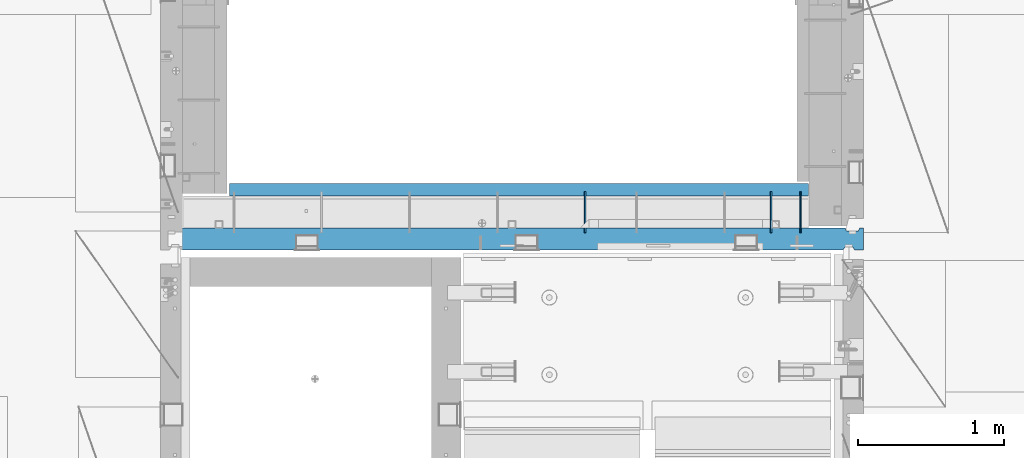
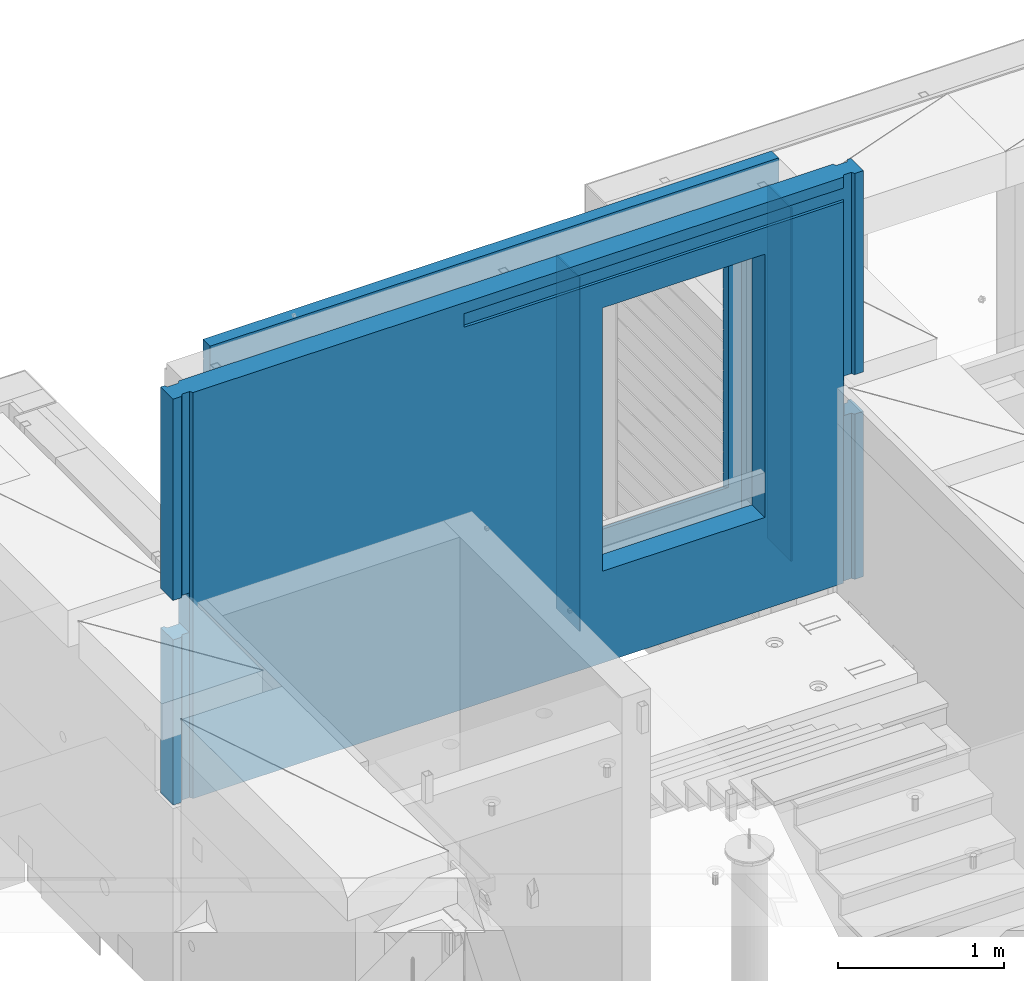
# One storey, part 239 of 350: 5 walls, 1 element without a shape of its own.
"""IFC2X3 building model written with IfcOpenShell, lengths in millimetres."""

import ifcopenshell
import ifcopenshell.guid

model = None  # the IFC model being written
_history = None  # IfcOwnerHistory: only IFC2X3 demands one
_inside = {}  # id of a spatial element -> (the spatial element, [elements in it])
_under = {}  # id of a project, library or spatial element -> (it, [spatial elements below it])
_declared = {}  # id of a project -> (the project, [libraries it declares])
_typed = {}  # id of a type object -> (the type object, [elements of that type])
_made_of = {}  # id of a material, layer set ... -> (it, [elements and type objects made of it])


def new_model(schema):
    """Start an empty IFC model of exactly this schema.

    Asked for "IFC4X3", IfcOpenShell would pick the latest addendum, in which some entities
    have other attributes; the version numbers below select the first issue.
    IFC2X3 requires an IfcOwnerHistory on every rooted entity: one is made here for all.
    """
    global model, _history
    if schema == "IFC4X3":
        model = ifcopenshell.file(schema_version=(4, 3, 0, 0))
    else:
        model = ifcopenshell.file(schema=schema)
    _inside.clear()
    _under.clear()
    _declared.clear()
    _typed.clear()
    _made_of.clear()
    _history = None
    if model.schema == "IFC2X3":
        org = make("IfcOrganization", Name="unknown")
        user = make(
            "IfcPersonAndOrganization",
            ThePerson=make("IfcPerson", FamilyName="unknown"),
            TheOrganization=org,
        )
        app = make(
            "IfcApplication",
            ApplicationDeveloper=org,
            Version="unknown",
            ApplicationFullName="unknown",
            ApplicationIdentifier="unknown",
        )
        _history = make(
            "IfcOwnerHistory",
            OwningUser=user,
            OwningApplication=app,
            ChangeAction="ADDED",
            CreationDate=0,
        )
    return model


def make(cls, **values):
    """One entity of the class cls with the attributes given. An attribute that is None is left unset."""
    return model.create_entity(
        cls, **{name: value for name, value in values.items() if value is not None}
    )


def rooted(cls, **values):
    """An entity with a GlobalId (a new one), such as an element, a storey or a relation."""
    return make(cls, GlobalId=ifcopenshell.guid.new(), OwnerHistory=_history, **values)


def si_unit(unit_type, name, prefix=None):
    """IfcSIUnit, for example si_unit("LENGTHUNIT", "METRE", prefix="MILLI")."""
    return make("IfcSIUnit", UnitType=unit_type, Prefix=prefix, Name=name)


def assignment(units):
    """IfcUnitAssignment: the units of a project."""
    return None if units is None else make("IfcUnitAssignment", Units=units)


def point(xyz):
    """IfcCartesianPoint."""
    return None if xyz is None else make("IfcCartesianPoint", Coordinates=xyz)


def direction(xyz):
    """IfcDirection."""
    return None if xyz is None else make("IfcDirection", DirectionRatios=xyz)


def frame(location, z_axis=None, x_axis=None):
    """IfcAxis2Placement3D, a coordinate frame: its origin and axes. An axis left out is left unset."""
    return make(
        "IfcAxis2Placement3D",
        Location=point(location),
        Axis=direction(z_axis),
        RefDirection=direction(x_axis),
    )


def origin_with_axes():
    """The frame at (0, 0, 0) with the z axis (0, 0, 1) and the x axis (1, 0, 0) written out."""
    return frame((0.0, 0.0, 0.0), z_axis=(0.0, 0.0, 1.0), x_axis=(1.0, 0.0, 0.0))


def place(relative_to, where):
    """IfcLocalPlacement: puts the frame where relative to a parent placement (None: the world)."""
    return make(
        "IfcLocalPlacement", PlacementRelTo=relative_to, RelativePlacement=where
    )


def context(
    kind, dimensions, precision=None, world=None, true_north=None, identifier=None
):
    """IfcGeometricRepresentationContext, for example the 3D "Model" context."""
    return make(
        "IfcGeometricRepresentationContext",
        ContextIdentifier=identifier,
        ContextType=kind,
        CoordinateSpaceDimension=dimensions,
        Precision=precision,
        WorldCoordinateSystem=world,
        TrueNorth=true_north,
    )


def subcontext(parent, identifier, kind, view, scale=None):
    """IfcGeometricRepresentationSubContext, for example "Body" below "Model"."""
    return make(
        "IfcGeometricRepresentationSubContext",
        ContextIdentifier=identifier,
        ContextType=kind,
        ParentContext=parent,
        TargetScale=scale,
        TargetView=view,
    )


def project(units=None, contexts=None):
    """IfcProject with its units and contexts."""
    return rooted(
        "IfcProject",
        Name="project",
        RepresentationContexts=contexts,
        UnitsInContext=assignment(units),
    )


def spatial(cls, under=None, at=None, **own):
    """A site, building, storey or space (cls), placed at a placement, below another one or the project."""
    s = rooted(cls, ObjectPlacement=at, **own)
    if under is not None:
        _under.setdefault(under.id(), (under, []))[1].append(s)
    return s


def faces_of(points, faces, orient=None, outer=None):
    """IfcFace entities. A face is a list of loops; a loop is a list of indices into points, from 0.

    orient and outer hold one flag for each loop. By default every Orientation is true, the
    first loop of a face is its IfcFaceOuterBound and the others are IfcFaceBound.
    """
    made = []
    for i, loops in enumerate(faces):
        bounds = []
        for j, loop in enumerate(loops):
            is_outer = j == 0 if outer is None else outer[i][j]
            bounds.append(
                make(
                    "IfcFaceOuterBound" if is_outer else "IfcFaceBound",
                    Bound=make("IfcPolyLoop", Polygon=[points[k] for k in loop]),
                    Orientation=True if orient is None else orient[i][j],
                )
            )
        made.append(make("IfcFace", Bounds=bounds))
    return made


def faceted_brep(points, faces, orient=None, outer=None, voids=None):
    """IfcFacetedBrep: a solid bounded by flat faces; with voids (closed shells), ...WithVoids."""
    shared = [point(p) for p in points]
    hull = make("IfcClosedShell", CfsFaces=faces_of(shared, faces, orient, outer))
    if voids is None:
        return make("IfcFacetedBrep", Outer=hull)
    return make(
        "IfcFacetedBrepWithVoids",
        Outer=hull,
        Voids=[
            make(cls, CfsFaces=faces_of(shared, fs, o, b)) for cls, fs, o, b in voids
        ],
    )


def shape(context_of_items, identifier, shape_type, items):
    """IfcShapeRepresentation: the items that make up one representation, for example the "Body"."""
    return make(
        "IfcShapeRepresentation",
        ContextOfItems=context_of_items,
        RepresentationIdentifier=identifier,
        RepresentationType=shape_type,
        Items=items,
    )


def material(Name=None, Category=None):
    """IfcMaterial."""
    return make("IfcMaterial", Name=Name, Category=Category)


def made_of(thing, what):
    """Note that an element or type object is made of a material, layer set ...; save() writes the relation."""
    if what is not None:
        _made_of.setdefault(what.id(), (what, []))[1].append(thing)
    return thing


def type_object(cls, material=None, **own):
    """A type object (cls), such as IfcWallType, which elements share."""
    return made_of(rooted(cls, **own), material)


def element(
    cls,
    number,
    at=None,
    inside=None,
    cuts=None,
    type_object=None,
    material=None,
    context=None,
    identifier="Body",
    shape_type=None,
    held_by="IfcProductDefinitionShape",
    body=None,
    shapes=None,
    **own,
):
    """One element of the class cls, such as IfcWall. Its Tag is "e" and its number.

    at: its placement. inside: the storey or other place that contains it. cuts: it is an
    opening in that element (IfcRelVoidsElement). A single representation is given by context,
    identifier, shape_type and body (its items); several are given by shapes. held_by: the class
    of the entity that holds the representations. save() writes the other relations.
    """
    e = rooted(cls, Tag="e%d" % number, ObjectPlacement=at, **own)
    if body is not None:
        shapes = [shape(context, identifier, shape_type, body)]
    if shapes is not None:
        e.Representation = make(held_by, Representations=shapes)
    if inside is not None:
        _inside.setdefault(inside.id(), (inside, []))[1].append(e)
    if cuts is not None:
        rooted(
            "IfcRelVoidsElement", RelatingBuildingElement=cuts, RelatedOpeningElement=e
        )
    if type_object is not None:
        _typed.setdefault(type_object.id(), (type_object, []))[1].append(e)
    return made_of(e, material)


def aggregate(whole, parts):
    """IfcRelAggregates: a whole, such as a stair, and the parts it consists of."""
    return rooted("IfcRelAggregates", RelatingObject=whole, RelatedObjects=parts)


def save(model, path):
    """Write the relations noted so far, then the file.

    IfcRelAggregates (storeys below a building ...), IfcRelContainedInSpatialStructure (elements
    in a storey), IfcRelDefinesByType, IfcRelAssociatesMaterial and IfcRelDeclares: one each for
    every whole, place, type object, material and project.
    """
    for whole, parts in _under.values():
        aggregate(whole, parts)
    for where, things in _inside.values():
        rooted(
            "IfcRelContainedInSpatialStructure",
            RelatedElements=things,
            RelatingStructure=where,
        )
    for kind, things in _typed.values():
        rooted("IfcRelDefinesByType", RelatedObjects=things, RelatingType=kind)
    for what, things in _made_of.values():
        rooted("IfcRelAssociatesMaterial", RelatedObjects=things, RelatingMaterial=what)
    for by, libraries in _declared.values():
        rooted("IfcRelDeclares", RelatingContext=by, RelatedDefinitions=libraries)
    model.write(path)


model = new_model("IFC2X3")

# Units and contexts
model_context = context("Model", 3, precision=1e-05, world=origin_with_axes())
body_context = subcontext(model_context, "Body", "Model", "MODEL_VIEW")
ifc_project = project(units=[si_unit("LENGTHUNIT", "METRE", prefix="MILLI"), si_unit("AREAUNIT", "SQUARE_METRE"), si_unit("VOLUMEUNIT", "CUBIC_METRE"), si_unit("MASSUNIT", "GRAM", prefix="KILO"), si_unit("TIMEUNIT", "SECOND"), si_unit("PLANEANGLEUNIT", "RADIAN"), si_unit("SOLIDANGLEUNIT", "STERADIAN"), si_unit("THERMODYNAMICTEMPERATUREUNIT", "DEGREE_CELSIUS"), si_unit("LUMINOUSINTENSITYUNIT", "LUMEN")], contexts=[model_context])

# Site, building, storey
site_placement = place(None, origin_with_axes())
site = spatial("IfcSite", under=ifc_project, at=site_placement, CompositionType="ELEMENT")
building_placement = place(site_placement, origin_with_axes())
building = spatial("IfcBuilding", under=site, at=building_placement, CompositionType="ELEMENT")
storey_placement = place(building_placement, origin_with_axes())
storey = spatial("IfcBuildingStorey", under=building, at=storey_placement, Name="2", CompositionType="ELEMENT", Elevation=0.0)

# Assembly, walls
assembly_placement = place(storey_placement, origin_with_axes())
assembly = element("IfcElementAssembly", 1, at=assembly_placement, inside=storey, AssemblyPlace="NOTDEFINED", PredefinedType="REINFORCEMENT_UNIT")
ifc_material_1 = material(Name="Undefined")
wall_type_1 = type_object("IfcWallType", PredefinedType="NOTDEFINED")
wall_1_placement = place(assembly_placement, frame((20510.0002441406, 20550.0, 87745.0), z_axis=(0.0, 0.0, 1.0), x_axis=(0.0, 1.0, 0.0)))
wall_1 = element("IfcWall", 2, at=wall_1_placement, type_object=wall_type_1, material=ifc_material_1, Name="(PD)", context=body_context, shape_type="Brep", body=[
    faceted_brep([(0.0, 5.0, -1300.0), (0.0, 5.0, 1300.0), (280.0, 5.0, 1300.0), (280.0, 5.0, -1300.0), (0.0, -5.0, 1300.0), (280.0, -5.0, 1300.0), (0.0, -5.0, -1300.0), (280.0, -5.0, -1300.0)], [[[0, 1, 2, 3]], [[1, 4, 5, 2]], [[4, 6, 7, 5]], [[6, 0, 3, 7]], [[5, 7, 3, 2]], [[6, 4, 1, 0]]]),
])
wall_2_placement = place(assembly_placement, frame((21780.0002441406, 20550.0, 87745.0), z_axis=(0.0, 0.0, 1.0), x_axis=(0.0, 1.0, 0.0)))
wall_2 = element("IfcWall", 3, at=wall_2_placement, type_object=wall_type_1, material=ifc_material_1, Name="(PD)", context=body_context, shape_type="Brep", body=[
    faceted_brep([(0.0, 5.0, -1300.0), (0.0, 5.0, 1300.0), (280.0, 5.0, 1300.0), (280.0, 5.0, -1300.0), (0.0, -5.0, 1300.0), (280.0, -5.0, 1300.0), (0.0, -5.0, -1300.0), (280.0, -5.0, -1300.0)], [[[0, 1, 2, 3]], [[1, 4, 5, 2]], [[4, 6, 7, 5]], [[6, 0, 3, 7]], [[5, 7, 3, 2]], [[6, 4, 1, 0]]]),
])
wall_3_placement = place(assembly_placement, frame((21980.0002441406, 20550.0, 87745.0), z_axis=(0.0, 0.0, 1.0), x_axis=(0.0, 1.0, 0.0)))
wall_3 = element("IfcWall", 4, at=wall_3_placement, type_object=wall_type_1, material=ifc_material_1, Name="(PD)", context=body_context, shape_type="Brep", body=[
    faceted_brep([(0.0, 5.0, -1300.0), (0.0, 5.0, 1300.0), (280.0, 5.0, 1300.0), (280.0, 5.0, -1300.0), (0.0, -5.0, 1300.0), (280.0, -5.0, 1300.0), (0.0, -5.0, -1300.0), (280.0, -5.0, -1300.0)], [[[0, 1, 2, 3]], [[1, 4, 5, 2]], [[4, 6, 7, 5]], [[6, 0, 3, 7]], [[5, 7, 3, 2]], [[6, 4, 1, 0]]]),
])
ifc_material_2 = material(Name="CONCRETE/C30/37")
wall_type_2 = type_object("IfcWallType", PredefinedType="NOTDEFINED")
wall_4_placement = place(assembly_placement, frame((18080.0, 20842.5, 87747.5), z_axis=(0.0, 0.0, 1.0), x_axis=(1.0, 0.0, 0.0)))
wall_4 = element("IfcWall", 5, at=wall_4_placement, type_object=wall_type_2, material=ifc_material_2, context=body_context, shape_type="Brep", body=[
    faceted_brep([(3955.0, 32.4999992499397, 1344.99999999921), (-3.63797880709171e-12, 32.4999992507037, 1344.99999999926), (-3.63797880709171e-12, 32.4999991127006, 1355.00000040044), (3955.0, 32.4999991119439, 1355.00000040044), (3955.0, 42.4999996032966, 1342.99999994476), (0.0, 42.5, 1342.99999994476), (3955.0, 42.4999992424127, 1206.99999988926), (0.0, 42.5, 1206.99999988925), (3955.0, 32.4999991119475, 1205.00000040044), (0.0, 32.4999991127006, 1205.00000040044), (3955.0, 32.4999992499506, 1194.99999999921), (0.0, 32.4999992507037, 1194.99999999926), (3955.0, 42.4999994790196, 1192.99999994478), (0.0, 42.5, 1192.99999994476), (3955.0, 32.499999111973, 1055.00000040044), (3955.0, 32.4999992499688, 1044.99999999921), (3613.82193430323, 32.4999992499688, 1044.99999999921), (3613.821934287, 32.499999111973, 1055.00000040044), (3955.0, 42.4999994184, 1042.99999994476), (3614.99840497971, 42.4999994684003, 1042.99999994476), (3955.0, 42.4999992424309, 906.999999889245), (3614.99840497971, 42.499999307558, 906.999999889245), (3955.0, 32.4999991119621, 905.000000400425), (3613.821934287, 32.4999991119621, 905.000000400425), (3955.0, 32.4999992499652, 894.9999999992), (3613.82193430323, 32.4999992499652, 894.9999999992), (3955.0, 42.4999993825222, 892.999999944761), (3614.99840497971, 42.499999435604, 892.999999944761), (3955.0, 42.4999992424418, 756.999999889231), (3614.99840497971, 42.4999993075689, 756.999999889231), (3955.0, 32.4999991119766, 755.000000400411), (3613.821934287, 32.4999991119766, 755.000000400411), (3955.0, 32.4999992499797, 744.999999999185), (3613.82193430324, 32.4999992499797, 744.999999999185), (3955.0, 42.4999993588208, 742.999999944746), (3614.99840497971, 42.4999994139398, 742.999999944746), (3955.0, 42.4999992424746, 606.999999889231), (3614.99840497971, 42.499999307598, 606.999999889231), (3955.0, 32.4999991120058, 605.000000400425), (3613.821934287, 32.4999991120058, 605.000000400425), (3955.0, 32.4999992499979, 594.9999999992), (3613.82193430324, 32.4999992499979, 594.9999999992), (3955.0, 42.4999993419697, 592.999999944746), (3614.99840497971, 42.4999993985402, 592.999999944746), (3955.0, 42.4999992424782, 456.99999988926), (3614.99840497971, 42.4999993076017, 456.99999988926), (3955.0, 32.499999112013, 455.00000040044), (3613.821934287, 32.499999112013, 455.00000040044), (3955.0, 32.4999992500161, 444.999999999214), (3613.82193430324, 32.4999992500161, 444.999999999214), (3955.0, 42.4999993293859, 442.999999944775), (3614.99840497971, 42.499999387037, 442.999999944775), (3955.0, 42.4999992424855, 306.999999889245), (3614.99840497971, 42.499999307609, 306.999999889245), (3955.0, 32.4999991120167, 305.000000400425), (3613.82193428701, 32.4999991120167, 305.000000400425), (3955.0, 32.4999992500234, 294.9999999992), (3613.82193430324, 32.4999992500234, 294.9999999992), (3955.0, 42.4999993196434, 292.999999944761), (3614.99840497971, 42.4999993781312, 292.999999944761), (3955.0, 42.4999992425037, 156.999999889245), (3614.99840497971, 42.4999993076235, 156.999999889245), (3955.0, 32.4999991120349, 155.000000400425), (3613.82193428701, 32.4999991120349, 155.000000400425), (3955.0, 32.4999992500379, 144.9999999992), (3613.82193430324, 32.4999992500379, 144.9999999992), (3955.0, 42.4999993118727, 142.999999944761), (3614.99840497971, 42.4999993710298, 142.999999944761), (3955.0, 42.4999992425255, 6.99999988924537), (3614.99840497971, 42.4999993076453, 6.99999988924537), (3955.0, 32.4999991120567, 5.0000004004396), (3613.82193428701, 32.4999991120567, 5.0000004004396), (3955.0, 32.4999992500489, -5.0000000007858), (3613.82193430325, 32.4999992500489, -5.0000000007858), (3955.0, 42.4999993095153, -7.00000005523907), (3614.99840497971, 42.4999993688762, -7.00000005523907), (3955.0, 42.4999992468911, -143.000000110784), (3614.99840497971, 42.4999993116326, -143.000000110784), (3955.0, 32.4999991164223, -144.999999599604), (3613.82193428752, 32.4999991164223, -144.999999599604), (3955.0, 32.4999992544181, -155.000000000829), (3613.82193430376, 32.4999992544181, -155.000000000829), (3955.0, 42.4999993037636, -157.000000055268), (3614.99840497971, 42.4999993636156, -157.000000055268), (3955.0, 42.4999992463599, -293.000000110755), (3614.99840497971, 42.4999993111487, -293.000000110755), (3955.0, 32.4999991158911, -294.999999599575), (3613.82193428746, 32.4999991158911, -294.999999599575), (3955.0, 32.4999992538869, -305.000000000786), (3613.82193430369, 32.4999992538869, -305.000000000786), (3955.0, 42.4999992988232, -307.000000055239), (3614.99840497971, 42.4999993591009, -307.000000055239), (3955.0, 42.4999992458288, -443.000000110755), (3614.99840497971, 42.4999993106612, -443.000000110755), (3955.0, 32.49999911536, -444.999999599575), (3613.8219342874, 32.49999911536, -444.999999599575), (3955.0, 32.4999992533558, -455.0000000008), (3613.82193430363, 32.4999992533558, -455.0000000008), (3955.0, 42.4999992945195, -457.000000055239), (3614.99840497971, 42.4999993551683, -457.000000055239), (3955.0, 42.4999992453049, -593.00000011074), (3614.99840497971, 42.4999993101846, -593.00000011074), (3955.0, 32.4999991148361, -594.99999959956), (3613.82193428733, 32.4999991148361, -594.99999959956), (3955.0, 32.4999992528319, -605.000000000786), (3613.82193430357, 32.4999992528319, -605.000000000786), (3955.0, 42.4999992907105, -607.000000055225), (3614.99840497971, 42.4999993516867, -607.000000055225), (3955.0, 42.4999992447629, -743.000000110755), (3614.99840497971, 42.4999993096899, -743.000000110755), (3955.0, 32.499999114294, -744.999999599575), (3613.82193428727, 32.499999114294, -744.999999599575), (3955.0, 32.4999992522935, -755.0000000008), (3613.82193430351, 32.4999992522935, -755.0000000008), (3955.0, 42.4999992873236, -757.000000055239), (3614.99840497971, 42.4999993485908, -757.000000055239), (0.0, -42.5, -1492.5), (0.0, 42.5, -1492.5), (3955.0, 42.5, -1492.5), (3955.0, -42.5, -1492.5), (0.0, 42.5, -1357.00000005524), (3955.0, 42.5, -1357.00000005524), (0.0, 32.4999992507037, -1355.00000000074), (3955.0, 32.4999992501653, -1355.00000000079), (0.0, 32.4999991127006, -1344.99999959956), (3955.0, 32.4999991121695, -1344.99999959956), (3955.0, 42.4999992426383, -1343.00000011075), (0.0, 42.5, -1343.00000011075), (0.0, 42.5, -1207.00000005524), (3955.0, 42.4999992789635, -1207.00000005522), (0.0, 32.4999992507037, -1205.00000000074), (3955.0, 32.4999992506928, -1205.00000000079), (0.0, 32.4999991127006, -1194.99999959956), (3955.0, 32.499999112697, -1194.99999959956), (3955.0, 42.4999992431658, -1193.00000011074), (0.0, 42.5, -1193.00000011075), (0.0, 42.5, -1057.00000005524), (3955.0, 42.4999992814919, -1057.00000005525), (0.0, 32.4999992507037, -1055.00000000074), (3955.0, 32.4999992512312, -1055.00000000081), (0.0, 32.4999991127006, -1044.99999959956), (3955.0, 32.4999991132318, -1044.99999959959), (3955.0, 42.4999992437006, -1043.00000011077), (0.0, 42.5, -1043.00000011075), (0.0, 42.5, -907.000000055239), (3955.0, 42.4999992842677, -907.000000055225), (0.0, 32.4999992507037, -905.000000000742), (3955.0, 32.499999251766, -905.000000000771), (0.0, 32.4999991127006, -894.99999959956), (3955.0, 32.4999991137665, -894.99999959956), (3955.0, 42.4999992442354, -893.00000011074), (0.0, 42.5, -893.000000110755), (0.0, 32.4999991127006, 1055.00000040044), (0.0, 42.5, 1056.99999988925), (2544.99840497971, 42.4999995125218, 1056.99999988925), (2546.17487567242, 32.499999111973, 1055.00000040044), (0.0, 32.4999992507037, 1044.99999999926), (2546.17487565618, 32.4999992499688, 1044.99999999921), (0.0, 42.5, 1042.99999994476), (2544.99840497971, 42.4999996257466, 1042.99999994476), (0.0, 42.5, 906.999999889245), (2544.99840497971, 42.4999995125145, 906.999999889245), (0.0, 32.4999991127006, 905.00000040044), (2546.17487567242, 32.4999991119621, 905.000000400425), (0.0, 32.4999992507037, 894.999999999258), (2546.17487565618, 32.4999992499652, 894.9999999992), (0.0, 42.5, 892.999999944761), (2544.99840497971, 42.49999960266, 892.999999944761), (0.0, 42.5, 756.999999889245), (2544.99840497971, 42.4999995125218, 756.999999889231), (0.0, 32.4999991127006, 755.00000040044), (2546.17487567242, 32.4999991119766, 755.000000400411), (0.0, 32.4999992507037, 744.999999999258), (2546.17487565618, 32.4999992499797, 744.999999999185), (0.0, 42.5, 742.999999944761), (2544.99840497971, 42.4999995874059, 742.999999944746), (0.0, 42.5, 606.999999889245), (2544.99840497971, 42.4999995125399, 606.999999889231), (3.63797880709171e-12, 32.4999991127006, 605.00000040044), (2546.17487567241, 32.4999991120058, 605.000000400425), (3.63797880709171e-12, 32.4999992507037, 594.999999999258), (2546.17487565618, 32.4999992499979, 594.9999999992), (0.0, 42.5, 592.999999944761), (2544.99840497971, 42.4999995765647, 592.999999944746), (0.0, 42.5, 456.999999889245), (2544.99840497971, 42.4999995125436, 456.99999988926), (0.0, 32.4999991127006, 455.00000040044), (2546.17487567241, 32.499999112013, 455.00000040044), (0.0, 32.4999992507037, 444.999999999258), (2546.17487565617, 32.4999992500161, 444.999999999214), (0.0, 42.5, 442.999999944761), (2544.99840497971, 42.4999995684666, 442.999999944775), (0.0, 42.5, 306.999999889245), (2544.99840497971, 42.4999995125509, 306.999999889245), (-3.63797880709171e-12, 32.4999991127006, 305.00000040044), (2546.17487567241, 32.4999991120167, 305.000000400425), (-3.63797880709171e-12, 32.4999992507037, 294.999999999258), (2546.17487565617, 32.4999992500234, 294.9999999992), (0.0, 42.5, 292.999999944761), (2544.99840497971, 42.4999995621984, 292.999999944761), (0.0, 42.5, 156.999999889245), (2544.99840497971, 42.4999995125581, 156.999999889245), (-3.63797880709171e-12, 32.4999991127006, 155.00000040044), (2546.17487567241, 32.4999991120349, 155.000000400425), (-3.63797880709171e-12, 32.4999992507037, 144.999999999258), (2546.17487565617, 32.4999992500379, 144.9999999992), (0.0, 42.5, 142.999999944761), (2544.99840497971, 42.4999995571998, 142.999999944761), (0.0, 42.5, 6.99999988924537), (2544.99840497971, 42.4999995125763, 6.99999988924537), (0.0, 32.4999991127006, 5.0000004004396), (2546.1748756724, 32.4999991120567, 5.0000004004396), (0.0, 32.4999992507037, -5.00000000074215), (2546.17487565617, 32.4999992500489, -5.0000000007858), (0.0, 42.5, -7.00000005523907), (2544.99840497971, 42.4999995556827, -7.00000005523907), (0.0, 42.5, -143.000000110755), (2544.99840497971, 42.4999995153812, -143.000000110784), (3.63797880709171e-12, 32.4999991127006, -144.99999959956), (2546.17487567189, 32.4999991164223, -144.999999599604), (3.63797880709171e-12, 32.4999992507037, -155.000000000742), (2546.17487565566, 32.4999992544181, -155.000000000829), (0.0, 42.5, -157.000000055239), (2544.99840497971, 42.4999995519793, -157.000000055268), (0.0, 42.5, -293.000000110755), (2544.99840497971, 42.4999995150429, -293.000000110755), (0.0, 32.4999991127006, -294.99999959956), (2546.17487567195, 32.4999991158911, -294.999999599575), (0.0, 32.4999992507037, -305.000000000742), (2546.17487565572, 32.4999992538869, -305.000000000786), (0.0, 42.5, -307.000000055239), (2544.99840497971, 42.4999995487997, -307.000000055239), (0.0, 42.5, -443.000000110755), (2544.99840497971, 42.4999995146973, -443.000000110755), (0.0, 32.4999991127006, -444.99999959956), (2546.17487567201, 32.49999911536, -444.999999599575), (0.0, 32.4999992507037, -455.000000000742), (2546.17487565578, 32.4999992533558, -455.0000000008), (0.0, 42.5, -457.000000055239), (2544.99840497971, 42.4999995460312, -457.000000055239), (0.0, 42.5, -593.000000110755), (2544.99840497971, 42.4999995143626, -593.00000011074), (3.63797880709171e-12, 32.4999991127006, -594.99999959956), (2546.17487567208, 32.4999991148361, -594.99999959956), (3.63797880709171e-12, 32.4999992507037, -605.000000000742), (2546.17487565584, 32.4999992528319, -605.000000000786), (0.0, 42.5, -607.000000055239), (2544.99840497971, 42.4999995435792, -607.000000055225), (0.0, 42.5, -743.000000110755), (2544.99840497971, 42.4999995140133, -743.000000110755), (0.0, 32.4999991127006, -744.99999959956), (2546.17487567214, 32.499999114294, -744.999999599575), (0.0, 32.4999992507037, -755.000000000742), (2546.17487565591, 32.4999992522935, -755.0000000008), (0.0, 42.5, -757.000000055239), (2544.99840497971, 42.4999995414, -757.000000055239), (2544.99840497971, 42.5, -857.5), (3614.99840497971, 42.5, -857.5), (2554.99840497971, -42.5, -807.5), (3604.99840497971, -42.5, -807.5), (0.0, -42.5, 1492.5), (3955.0, -42.5, 1492.5), (2554.99840497971, -42.5, 1082.5), (2554.99840497971, -42.5, 1087.5), (3604.99840497971, -42.5, 1087.5), (3604.99840497971, -42.5, 1082.5), (0.0, 42.5, 1492.5), (3955.0, 42.5, 1492.5), (3955.0, 42.4999992424164, 1356.99999988925), (0.0, 42.5, 1356.99999988925), (3955.0, 42.4999992424455, 1056.99999988925), (2554.99840497971, 42.5, 1082.5), (2544.99840497971, 42.5, 1082.5), (3614.99840497971, 42.4999993075689, 1056.99999988925), (3614.99840497971, 42.5, 1082.5), (3604.99840497971, 42.5, 1082.5)], [[[0, 1, 2, 3]], [[4, 5, 1, 0]], [[6, 7, 5, 4]], [[6, 8, 9, 7]], [[10, 11, 9, 8]], [[12, 13, 11, 10]], [[14, 15, 16, 17]], [[15, 18, 19, 16]], [[18, 20, 21, 19]], [[20, 22, 23, 21]], [[22, 24, 25, 23]], [[24, 26, 27, 25]], [[26, 28, 29, 27]], [[28, 30, 31, 29]], [[30, 32, 33, 31]], [[32, 34, 35, 33]], [[34, 36, 37, 35]], [[36, 38, 39, 37]], [[38, 40, 41, 39]], [[40, 42, 43, 41]], [[42, 44, 45, 43]], [[44, 46, 47, 45]], [[46, 48, 49, 47]], [[48, 50, 51, 49]], [[50, 52, 53, 51]], [[52, 54, 55, 53]], [[54, 56, 57, 55]], [[56, 58, 59, 57]], [[58, 60, 61, 59]], [[60, 62, 63, 61]], [[62, 64, 65, 63]], [[64, 66, 67, 65]], [[66, 68, 69, 67]], [[68, 70, 71, 69]], [[70, 72, 73, 71]], [[72, 74, 75, 73]], [[74, 76, 77, 75]], [[76, 78, 79, 77]], [[78, 80, 81, 79]], [[80, 82, 83, 81]], [[82, 84, 85, 83]], [[84, 86, 87, 85]], [[86, 88, 89, 87]], [[88, 90, 91, 89]], [[90, 92, 93, 91]], [[92, 94, 95, 93]], [[94, 96, 97, 95]], [[96, 98, 99, 97]], [[98, 100, 101, 99]], [[100, 102, 103, 101]], [[102, 104, 105, 103]], [[104, 106, 107, 105]], [[106, 108, 109, 107]], [[108, 110, 111, 109]], [[110, 112, 113, 111]], [[112, 114, 115, 113]], [[116, 117, 118, 119]], [[118, 117, 120, 121]], [[121, 120, 122, 123]], [[123, 122, 124, 125]], [[126, 125, 124, 127]], [[126, 127, 128, 129]], [[129, 128, 130, 131]], [[131, 130, 132, 133]], [[134, 133, 132, 135]], [[134, 135, 136, 137]], [[137, 136, 138, 139]], [[139, 138, 140, 141]], [[142, 141, 140, 143]], [[142, 143, 144, 145]], [[145, 144, 146, 147]], [[147, 146, 148, 149]], [[150, 149, 148, 151]], [[152, 153, 154, 155]], [[156, 152, 155, 157]], [[158, 156, 157, 159]], [[160, 158, 159, 161]], [[162, 160, 161, 163]], [[164, 162, 163, 165]], [[166, 164, 165, 167]], [[168, 166, 167, 169]], [[170, 168, 169, 171]], [[172, 170, 171, 173]], [[174, 172, 173, 175]], [[176, 174, 175, 177]], [[178, 176, 177, 179]], [[180, 178, 179, 181]], [[182, 180, 181, 183]], [[184, 182, 183, 185]], [[186, 184, 185, 187]], [[188, 186, 187, 189]], [[190, 188, 189, 191]], [[192, 190, 191, 193]], [[194, 192, 193, 195]], [[196, 194, 195, 197]], [[198, 196, 197, 199]], [[200, 198, 199, 201]], [[202, 200, 201, 203]], [[204, 202, 203, 205]], [[206, 204, 205, 207]], [[208, 206, 207, 209]], [[210, 208, 209, 211]], [[212, 210, 211, 213]], [[214, 212, 213, 215]], [[216, 214, 215, 217]], [[218, 216, 217, 219]], [[220, 218, 219, 221]], [[222, 220, 221, 223]], [[224, 222, 223, 225]], [[226, 224, 225, 227]], [[228, 226, 227, 229]], [[230, 228, 229, 231]], [[232, 230, 231, 233]], [[234, 232, 233, 235]], [[236, 234, 235, 237]], [[238, 236, 237, 239]], [[240, 238, 239, 241]], [[242, 240, 241, 243]], [[244, 242, 243, 245]], [[246, 244, 245, 247]], [[248, 246, 247, 249]], [[250, 248, 249, 251]], [[252, 250, 251, 253]], [[254, 252, 253, 255]], [[114, 150, 151, 254, 255, 256, 257, 115]], [[256, 258, 259, 257]], [[260, 116, 119, 261], [259, 258, 262, 263, 264, 265]], [[266, 260, 261, 267]], [[266, 267, 268, 269]], [[1, 5, 7, 9, 11, 13, 153, 152, 156, 158, 160, 162, 164, 166, 168, 170, 172, 174, 176, 178, 180, 182, 184, 186, 188, 190, 192, 194, 196, 198, 200, 202, 204, 206, 208, 210, 212, 214, 216, 218, 220, 222, 224, 226, 228, 230, 232, 234, 236, 238, 240, 242, 244, 246, 248, 250, 252, 254, 151, 148, 146, 144, 143, 140, 138, 136, 135, 132, 130, 128, 127, 124, 122, 120, 117, 116, 260, 266, 269, 2]], [[268, 3, 2, 269]], [[267, 261, 119, 118, 121, 123, 125, 126, 129, 131, 133, 134, 137, 139, 141, 142, 145, 147, 149, 150, 114, 112, 110, 108, 106, 104, 102, 100, 98, 96, 94, 92, 90, 88, 86, 84, 82, 80, 78, 76, 74, 72, 70, 68, 66, 64, 62, 60, 58, 56, 54, 52, 50, 48, 46, 44, 42, 40, 38, 36, 34, 32, 30, 28, 26, 24, 22, 20, 18, 15, 14, 270, 12, 10, 8, 6, 4, 0, 3, 268]], [[271, 272, 154, 153, 13, 12, 270, 273, 274, 275]], [[262, 258, 256, 255, 253, 251, 249, 247, 245, 243, 241, 239, 237, 235, 233, 231, 229, 227, 225, 223, 221, 219, 217, 215, 213, 211, 209, 207, 205, 203, 201, 199, 197, 195, 193, 191, 189, 187, 185, 183, 181, 179, 177, 175, 173, 171, 169, 167, 165, 163, 161, 159, 157, 155, 154, 272, 263]], [[271, 275, 274, 264, 263, 272]], [[273, 17, 16, 19, 21, 23, 25, 27, 29, 31, 33, 35, 37, 39, 41, 43, 45, 47, 49, 51, 53, 55, 57, 59, 61, 63, 65, 67, 69, 71, 73, 75, 77, 79, 81, 83, 85, 87, 89, 91, 93, 95, 97, 99, 101, 103, 105, 107, 109, 111, 113, 115, 257, 259, 265, 264, 274]], [[270, 14, 17, 273]]]),
])
ifc_material_3 = material(Name="CONCRETE/C25/30")
wall_type_3 = type_object("IfcWallType", PredefinedType="NOTDEFINED")
wall_5_placement = place(assembly_placement, frame((17610.0, 20505.0, 87747.5), z_axis=(0.0, 0.0, 1.0), x_axis=(1.0, 0.0, 0.0)))
wall_5 = element("IfcWall", 6, at=wall_5_placement, type_object=wall_type_3, material=ifc_material_3, context=body_context, shape_type="Brep", body=[
    faceted_brep([(115.000000752763, 54.9999994575555, -277.499999999956), (35.0000012841592, 54.9999974671882, -277.499999999956), (25.0000034119694, 75.0, -277.499999999956), (0.0, 75.0, -277.499999999956), (0.0, -75.0, -277.499999999956), (59.9999958419066, -75.0, -277.499999999956), (73.0000021298038, -54.9999990274482, -277.499999999956), (125.000000000065, -54.9999987501142, -277.499999999956), (124.999999335741, 75.0, -277.499999999956), (125.000000000065, 74.9999996833285, 12.5000000000582), (125.000000000065, -54.9999987501142, 12.5000000000582), (73.0000021298038, -54.9999990274482, 12.5000000000437), (59.9999958419066, -75.0, 12.5000000000437), (0.0, -75.0, 12.5000000000437), (0.0, 75.0, 12.5000000000437), (25.0000034119694, 75.0, 12.5000000000437), (35.0000012841592, 54.9999974671882, 12.5000000000437), (115.000000752763, 54.9999994575555, 12.5000000000582), (4684.99999994252, 55.0000001373264, 1492.5), (4765.0000011171, 55.0000001731059, 1492.5), (4765.0000011171, 55.0000001731059, 12.5000000000582), (4684.99999994252, 55.0000001373264, 12.5000000000437), (2023.0, -55.0, 1412.5), (2023.0, -55.0, 1312.5), (4673.0, -55.0, 1312.5), (4673.0, -55.0, 1412.5), (4659.9999958419, -75.0, 1492.5), (4659.9999958419, -75.0, 1412.5), (4672.99999996855, -54.9999999109459, 1492.5), (2023.0, -75.0, 1412.5), (2023.0, -75.0, 1312.5), (4659.9999958419, -75.0, 1312.5), (4659.9999958419, -75.0, -1492.5), (4672.99999996855, -54.9999999109459, -1492.5), (4726.9999998731, -54.9999987450756, -1492.5), (4740.00000278436, -75.0, -1492.5), (4740.00000278436, -75.0000009276337, -277.499999999956), (4726.9999998731, -54.9999987450756, -277.499999999956), (4684.99999994252, 55.0000001373264, -1492.5), (4675.0, 75.0, -1492.5), (4675.0, 75.0, -277.499999999956), (4684.99999994252, 55.0000001373264, -277.499999999956), (4765.0000011171, 55.0000001731059, -1492.5), (4765.0000011171, 55.0000001731059, -277.499999999956), (4774.99999933574, 75.0, -1492.5), (4774.99999933574, 75.0000000182044, -277.499999999956), (4800.0, 75.0, -1492.5), (4800.0, 75.0, -277.499999999956), (4800.0, -75.0, -1492.5), (4800.0, -75.0, -277.499999999956), (4674.9999998891, -54.9999999110878, -277.499999999956), (4675.0, 75.0, 12.5000000000437), (4675.00000000007, -54.9999999110878, 12.5000000000437), (4726.9999998731, -54.9999987450756, 1492.5), (4726.9999998731, -54.9999987450756, 12.5000000000582), (4740.00000278436, -75.0000022790009, 1492.5), (4740.00000278436, -75.0000011490447, 12.5000000000582), (4800.0, -75.0, 1492.5), (4800.0, -75.0, 12.5000000000582), (4800.0, 75.0, 1492.5), (4800.00000000007, 74.9999996833285, 12.5000000000582), (4774.99999933574, 75.0000000447253, 1492.5), (4774.99999933574, 75.0000000225482, 12.5000000000582), (4675.0, 75.0, 1492.5), (35.0000012841592, 54.9999974671882, 1492.5), (25.0000034119694, 75.0, 1492.5), (0.0, 75.0, 1492.5), (0.0, -75.0, 1492.5), (59.9999958419066, -75.0, 1492.5), (73.0000021298038, -54.9999990274482, 1492.5), (126.999999875414, -54.9999987394476, 1492.5), (140.000002784363, -75.0, 1492.5), (124.999999335741, 75.0, 1492.5), (115.000000752763, 54.9999994575555, 1492.5), (73.0000021298038, -54.9999990274482, -1492.5), (126.999999875414, -54.9999987394476, -1492.5), (59.9999958419066, -75.0, -1492.5), (0.0, -75.0, -1492.5), (0.0, 75.0, -1492.5), (25.0000034119694, 75.0, -1492.5), (35.0000012841592, 54.9999974671882, -1492.5), (115.000000752763, 54.9999994575555, -1492.5), (124.999999335741, 75.0, -1492.5), (140.000002784363, -75.0, -1492.5), (2984.99840497971, -75.0000022790045, -817.5), (2984.99840497971, -75.0000022790045, 1117.5), (4114.99840497971, -75.0000022790045, 1117.5), (4114.99840497971, -75.0000022790045, -817.5), (2989.05245909535, 75.0, 1113.44594588435), (2989.05245909535, 75.0, -813.445945884348), (4110.94435086406, 75.0, -813.445945884348), (4110.94435086406, 75.0, 1113.44594588435)], [[[0, 1, 2, 3, 4, 5, 6, 7, 8]], [[9, 10, 11, 12, 13, 14, 15, 16, 17]], [[8, 7, 10, 9]], [[18, 19, 20, 21]], [[22, 23, 24, 25]], [[26, 27, 25, 28]], [[29, 22, 25, 27]], [[30, 23, 22, 29]], [[23, 30, 31, 24]], [[31, 32, 33, 24]], [[34, 35, 36, 37]], [[38, 39, 40, 41]], [[42, 38, 41, 43]], [[44, 42, 43, 45]], [[46, 44, 45, 47]], [[48, 46, 47, 49]], [[35, 48, 49, 36]], [[47, 45, 43, 41, 40, 50, 37, 36, 49]], [[51, 52, 50, 40]], [[53, 28, 25, 24, 33, 34, 37, 50, 52, 54]], [[55, 53, 54, 56]], [[57, 55, 56, 58]], [[59, 57, 58, 60]], [[61, 59, 60, 62]], [[19, 61, 62, 20]], [[60, 58, 56, 54, 52, 51, 21, 20, 62]], [[63, 18, 21, 51]], [[64, 65, 66, 67, 68, 69, 70, 71, 26, 28, 53, 55, 57, 59, 61, 19, 18, 63, 72, 73]], [[73, 72, 9, 17]], [[64, 73, 17, 16]], [[65, 64, 16, 15]], [[66, 65, 15, 14]], [[67, 66, 14, 13]], [[68, 67, 13, 12]], [[69, 68, 12, 11]], [[6, 74, 75, 70, 69, 11, 10, 7]], [[76, 74, 6, 5]], [[77, 76, 5, 4]], [[78, 77, 4, 3]], [[79, 78, 3, 2]], [[80, 79, 2, 1]], [[81, 80, 1, 0]], [[82, 81, 0, 8]], [[39, 38, 42, 44, 46, 48, 35, 34, 33, 32, 83, 75, 74, 76, 77, 78, 79, 80, 81, 82]], [[71, 70, 75, 83]], [[32, 31, 30, 29, 27, 26, 71, 83], [84, 85, 86, 87]], [[88, 85, 84, 89]], [[87, 90, 89, 84]], [[86, 91, 90, 87]], [[85, 88, 91, 86]], [[72, 63, 51, 40, 39, 82, 8, 9], [89, 90, 91, 88]]]),
])
aggregate(assembly, [wall_4, wall_1, wall_2, wall_3, wall_5])

save(model, "model.ifc")
